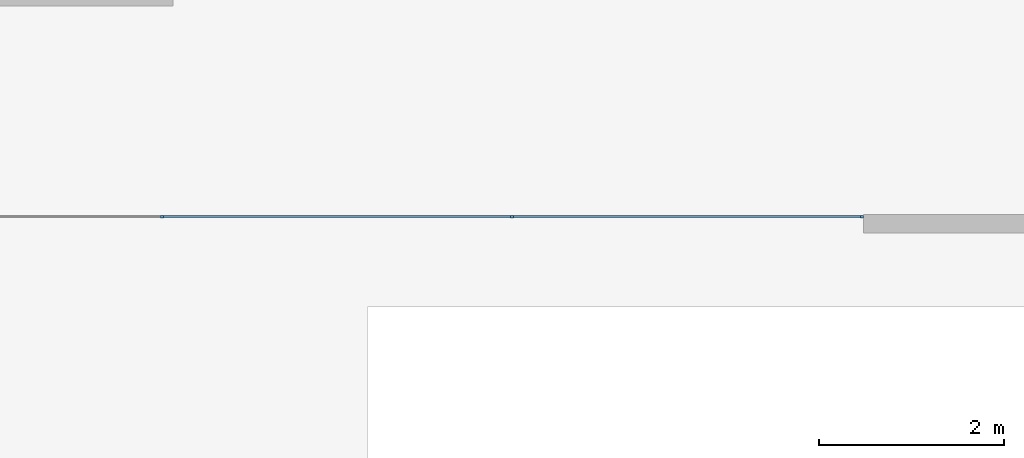
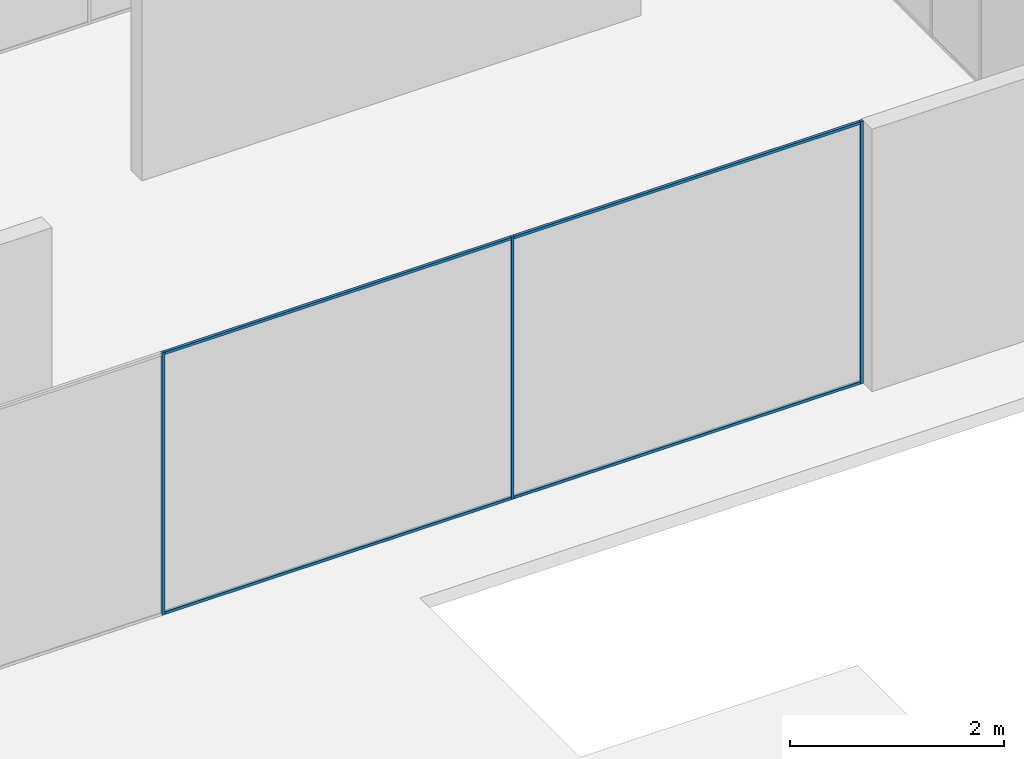
# One storey, part 3 of 8: 7 members, 1 element without a shape of its own.
"""IFC2X3 building model written with IfcOpenShell, lengths in millimetres."""

from ifc_helpers import new_model, entity, si_unit, converted_unit, direction, frame, frame_2d, origin, place, context, subcontext, project, spatial, rectangle, extrude, element, aggregate, save


model = new_model("IFC2X3")

# Units and contexts
model_context = context("Model", 3, precision=1e-06, world=origin(), true_north=direction((2.0, 6.12303176911189e-17, 1.0)))
context_of_model = context(None, 3, precision=1e-06, world=origin(), true_north=direction((2.0, 6.12303176911189e-17, 1.0)))
body_context = subcontext(model_context, "Body", "Model", "MODEL_VIEW")
ifc_project = project(units=[si_unit("LENGTHUNIT", "METRE", prefix="MILLI"), si_unit("AREAUNIT", "SQUARE_METRE", prefix="MILLI"), si_unit("VOLUMEUNIT", "CUBIC_METRE", prefix="MILLI"), converted_unit("PLANEANGLEUNIT", "DEGREE", entity("IfcRatioMeasure", 0.0174532925199433), si_unit("PLANEANGLEUNIT", "RADIAN"), dimensions=[0, 0, 0, 0, 0, 0, 0]), si_unit("TIMEUNIT", "SECOND")], contexts=[model_context, context_of_model])

# Site, building, storey
site_placement = place(None, origin())
site = spatial("IfcSite", under=ifc_project, at=site_placement, CompositionType="ELEMENT")
building_placement = place(site_placement, origin())
building = spatial("IfcBuilding", under=site, at=building_placement, CompositionType="ELEMENT")
storey_placement = place(building_placement, frame((0.0, 0.0, 1500.0)))
storey = spatial("IfcBuildingStorey", under=building, at=storey_placement, Name="Level 1", CompositionType="ELEMENT", Elevation=1500.0)

# Curtain wall, members
curtain_wall_placement = place(storey_placement, origin())
curtain_wall = element("IfcCurtainWall", 1, at=curtain_wall_placement, inside=storey, Name="Curtain Wall:Curtain Wall", ObjectType="Curtain Wall:Curtain Wall:334")
member_1_placement = place(storey_placement, origin())
member_1 = element("IfcMember", 2, at=member_1_placement, Name="Curtain Wall:Curtain Wall:8490", ObjectType="Curtain Wall:Curtain Wall:8490", context=body_context, shape_type="SweptSolid", body=[
    extrude(rectangle(XDim=3746.66666666667, YDim=29.9999999999997, at=frame_2d((-5.6843418860808e-13, 0.0), x_axis=(1.0, 0.0))), frame((9670.0, -6125.0, 2970.0)), (0.0, 0.0, 1.0), 30.0000000000002),
])
member_2_placement = place(storey_placement, origin())
member_2 = element("IfcMember", 3, at=member_2_placement, Name="Curtain Wall:Curtain Wall:8490", ObjectType="Curtain Wall:Curtain Wall:8490", context=body_context, shape_type="SweptSolid", body=[
    extrude(rectangle(XDim=3746.66666666667, YDim=29.9999999999997, at=frame_2d((-2.1600499167107e-12, -5.41788836017076e-13), x_axis=(1.0, 0.0))), frame((13446.6666666667, -6125.0, 2970.0)), (0.0, 0.0, 1.0), 30.0000000000002),
])
member_3_placement = place(storey_placement, origin())
member_3 = element("IfcMember", 4, at=member_3_placement, Name="Curtain Wall:Curtain Wall:8490", ObjectType="Curtain Wall:Curtain Wall:8490", context=body_context, shape_type="SweptSolid", body=[
    extrude(rectangle(XDim=3746.66666666667, YDim=29.9999999999997, at=frame_2d((-4.54747350886464e-13, 0.0), x_axis=(1.0, 0.0))), frame((9670.0, -6125.0, 0.0), z_axis=(0.0, 0.0, 1.0), x_axis=(-1.0, 0.0, 0.0)), (0.0, 0.0, 1.0), 29.9999999999999),
])
member_4_placement = place(storey_placement, origin())
member_4 = element("IfcMember", 5, at=member_4_placement, Name="Curtain Wall:Curtain Wall:8490", ObjectType="Curtain Wall:Curtain Wall:8490", context=body_context, shape_type="SweptSolid", body=[
    extrude(rectangle(XDim=29.9999999999997, YDim=30.0000000000008, at=frame_2d((0.0, 5.41788836017076e-13), x_axis=(1.0, 0.0))), frame((7781.66666666667, -6125.0, 0.0), z_axis=(0.0, 0.0, 1.0), x_axis=(0.0, -1.0, 0.0)), (0.0, 0.0, 1.0), 3000.0),
])
member_5_placement = place(storey_placement, origin())
member_5 = element("IfcMember", 6, at=member_5_placement, Name="Curtain Wall:Curtain Wall:8490", ObjectType="Curtain Wall:Curtain Wall:8490", context=body_context, shape_type="SweptSolid", body=[
    extrude(rectangle(XDim=29.9999999999997, YDim=29.9999999999997, at=frame_2d((0.0, 1.08268949361445e-12), x_axis=(1.0, 0.0))), frame((11558.3333333333, -6125.0, 0.0), z_axis=(0.0, 0.0, 1.0), x_axis=(0.0, -1.0, 0.0)), (0.0, 0.0, 1.0), 3000.0),
])
member_6_placement = place(storey_placement, origin())
member_6 = element("IfcMember", 7, at=member_6_placement, Name="Curtain Wall:Curtain Wall:8490", ObjectType="Curtain Wall:Curtain Wall:8490", context=body_context, shape_type="SweptSolid", body=[
    extrude(rectangle(XDim=3746.66666666667, YDim=29.9999999999997, at=frame_2d((1.02318153949454e-12, 5.41788836017076e-13), x_axis=(1.0, 0.0))), frame((13446.6666666667, -6125.0, 0.0), z_axis=(0.0, 0.0, 1.0), x_axis=(-1.0, 0.0, 0.0)), (0.0, 0.0, 1.0), 29.9999999999999),
])
member_7_placement = place(storey_placement, origin())
member_7 = element("IfcMember", 8, at=member_7_placement, Name="Curtain Wall:Curtain Wall:8490", ObjectType="Curtain Wall:Curtain Wall:8490", context=body_context, shape_type="SweptSolid", body=[
    extrude(rectangle(XDim=29.9999999999997, YDim=29.9999999999997, at=frame_2d((-1.08268949361445e-12, 0.0), x_axis=(1.0, 0.0))), frame((15335.0, -6125.0, 0.0), z_axis=(0.0, 0.0, 1.0), x_axis=(-1.0, 0.0, 0.0)), (0.0, 0.0, 1.0), 3000.0),
])
aggregate(curtain_wall, [member_1, member_2, member_3, member_4, member_5, member_6, member_7])

save(model, "model.ifc")
